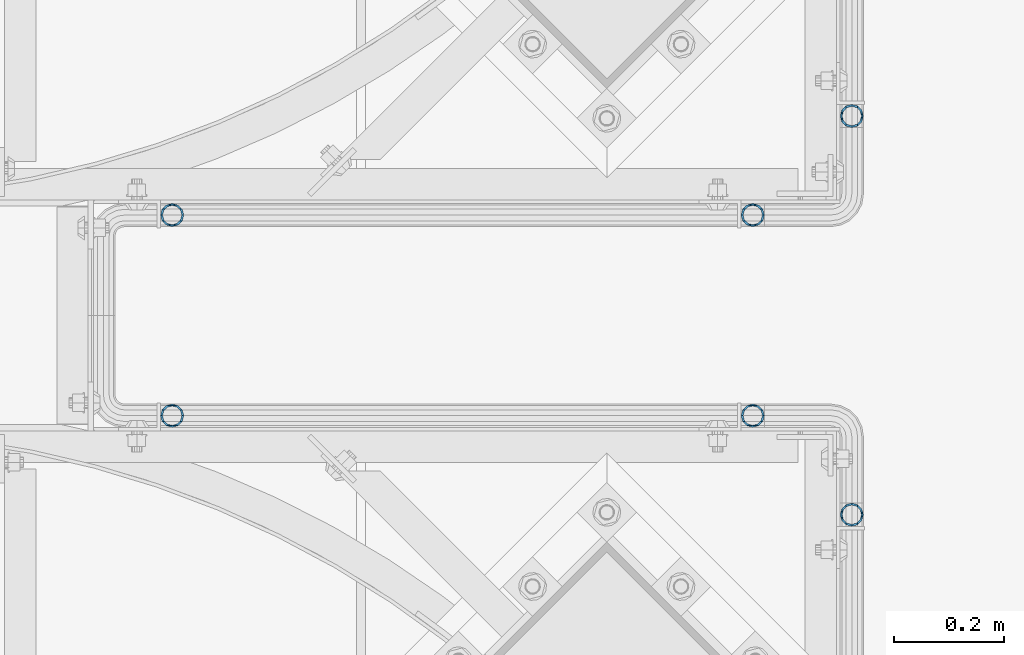
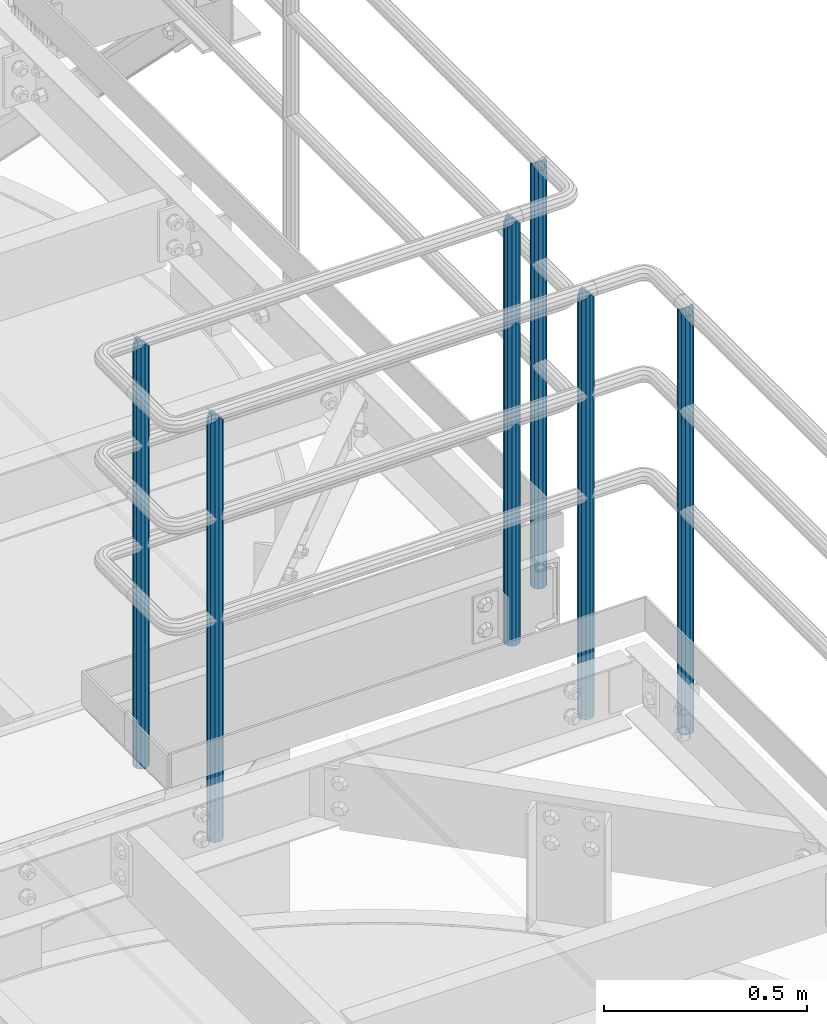
# One storey, part 553 of 1876: 6 columns, 4 elements without a shape of their own.
"""IFC2X3 building model written with IfcOpenShell, lengths in millimetres."""

from ifc_helpers import new_model, si_unit, frame, origin_with_axes, place, context, subcontext, project, spatial, faceted_brep, material, type_object, element, aggregate, save


model = new_model("IFC2X3")

# Units and contexts
model_context = context("Model", 3, precision=1e-05, world=origin_with_axes())
body_context = subcontext(model_context, "Body", "Model", "MODEL_VIEW")
ifc_project = project(units=[si_unit("LENGTHUNIT", "METRE", prefix="MILLI"), si_unit("AREAUNIT", "SQUARE_METRE"), si_unit("VOLUMEUNIT", "CUBIC_METRE"), si_unit("MASSUNIT", "GRAM", prefix="KILO"), si_unit("TIMEUNIT", "SECOND"), si_unit("PLANEANGLEUNIT", "RADIAN"), si_unit("SOLIDANGLEUNIT", "STERADIAN"), si_unit("THERMODYNAMICTEMPERATUREUNIT", "DEGREE_CELSIUS"), si_unit("LUMINOUSINTENSITYUNIT", "LUMEN")], contexts=[model_context])

# Site, building, storey
site_placement = place(None, origin_with_axes())
site = spatial("IfcSite", under=ifc_project, at=site_placement, CompositionType="ELEMENT")
building_placement = place(site_placement, origin_with_axes())
building = spatial("IfcBuilding", under=site, at=building_placement, Name="Undefined", CompositionType="ELEMENT")
storey_placement = place(building_placement, origin_with_axes())
storey = spatial("IfcBuildingStorey", under=building, at=storey_placement, Name="Undefined", CompositionType="ELEMENT", Elevation=0.0)

# Assembly, columns
assembly_1_placement = place(storey_placement, origin_with_axes())
assembly_1 = element("IfcElementAssembly", 1, at=assembly_1_placement, inside=storey, Name="HANDRAIL", AssemblyPlace="NOTDEFINED", PredefinedType="RIGID_FRAME")
ifc_material = material()
column_type = type_object("IfcColumnType", Name="PIPE1-1/4STD", PredefinedType="NOTDEFINED")
column_1_placement = place(assembly_1_placement, frame((6845.30474593762, -11381.1963554687, 7813.675), z_axis=(0.0, 1.0, 0.0), x_axis=(0.0, 0.0, 1.0)))
column_1 = element("IfcColumn", 2, at=column_1_placement, type_object=column_type, material=ifc_material, Name="POST", ObjectType="PIPE1-1/4STD", context=body_context, shape_type="Brep", body=[
    faceted_brep([(1276.35, 0.0, -21.0820000000003), (1265.809, 10.5410000000002, -18.2575475625836), (1265.809, -10.5410000000002, -18.2575475625836), (1257.61603877328, 15.1779612267264, 8.76299999999992), (1255.268, 17.5259999999998, 0.0), (1255.268, 21.0820000000003, 0.0), (1258.09245243742, 18.2575475625836, 10.5410000000002), (1258.09245243742, 13.3999612267262, 10.5410000000002), (1258.09245243742, 13.3999612267262, -10.5410000000002), (1258.09245243742, 18.2575475625836, -10.5410000000002), (1257.61603877328, 15.1779612267264, -8.76299999999992), (1262.72937633681, 8.76299999999992, -15.1779612267255), (1265.07741511008, 0.0, -17.5259999999998), (1262.72937633681, -8.76299999999992, -15.1779612267255), (1258.09245243741, -13.3999612267244, -10.541000000002), (1258.09245243742, -18.2575475625836, -10.5409999999993), (1257.61602877145, -15.1779612267264, -8.76300000000083), (1255.268, -17.5259999999998, 0.0), (1255.268, -21.0820000000003, 0.0), (1257.61604877511, -15.1779612267264, 8.76300000000083), (1258.09245243741, -13.399961226728, 10.5409999999983), (1258.09245243742, -18.2575475625836, 10.5409999999993), (1276.35, 0.0, 21.0820000000003), (1265.809, -10.5410000000002, 18.2575475625836), (1265.809, 10.5410000000002, 18.2575475625836), (1262.72941366414, -8.76299999999992, 15.1779612267264), (1265.07745243742, 0.0, 17.5259999999998), (1262.72941366414, 8.76299999999992, 15.1779612267264), (0.0, -18.2575475625836, -10.5409999999993), (0.0, -10.5410000000002, -18.2575475625836), (-4.28826751885936e-09, 0.0, -21.0820000000003), (0.0, 10.5410000000002, -18.2575475625836), (0.0, 18.2575475625836, -10.5409999999993), (9.09494701772928e-13, 21.0820000000003, 0.0), (0.0, 18.2575475625836, 10.5409999999993), (0.0, 10.5410000000002, 18.2575475625836), (0.0, 0.0, 21.0820000000003), (0.0, -18.2575475625836, 10.5409999999993), (9.09494701772928e-13, -21.0820000000003, 0.0), (0.0, -10.5410000000002, 18.2575475625836), (0.0, -15.1779612267264, -8.76300000000083), (0.0, -8.76299999999992, -15.1779612267255), (0.0, 0.0, -17.5259999999998), (0.0, 8.76299999999992, -15.1779612267255), (0.0, 15.1779612267264, -8.76300000000083), (0.0, 17.5259999999998, 0.0), (0.0, 15.1779612267264, 8.76300000000083), (0.0, 8.76299999999992, 15.1779612267255), (0.0, 0.0, 17.5259999999998), (0.0, -8.76299999999992, 15.1779612267255), (0.0, -15.1779612267264, 8.76300000000083), (0.0, -17.5259999999998, 0.0)], [[[0, 1, 2]], [[3, 4, 5, 6, 7]], [[8, 9, 5, 4, 10]], [[2, 1, 9, 8, 11, 12, 13, 14, 15]], [[15, 14, 16, 17, 18]], [[18, 17, 19, 20, 21]], [[22, 23, 24]], [[21, 20, 25, 26, 27, 7, 6, 24, 23]], [[28, 29, 2, 15]], [[29, 30, 0, 2]], [[30, 31, 1, 0]], [[31, 32, 9, 1]], [[32, 33, 5, 9]], [[33, 34, 6, 5]], [[34, 35, 24, 6]], [[35, 36, 22, 24]], [[37, 38, 18, 21]], [[39, 37, 21, 23]], [[36, 39, 23, 22]], [[38, 28, 15, 18]], [[37, 39, 36, 35, 34, 33, 32, 31, 30, 29, 28, 38], [40, 41, 42, 43, 44, 45, 46, 47, 48, 49, 50, 51]], [[49, 48, 26, 25]], [[19, 50, 49, 25, 20]], [[51, 50, 19, 17]], [[40, 51, 17, 16]], [[41, 40, 16, 14, 13]], [[42, 41, 13, 12]], [[43, 42, 12, 11]], [[10, 44, 43, 11, 8]], [[45, 44, 10, 4]], [[46, 45, 4, 3]], [[47, 46, 3, 7, 27]], [[48, 47, 27, 26]]]),
])
column_2_placement = place(assembly_1_placement, frame((5791.20474593762, -11381.1963554687, 7813.675), z_axis=(0.0, 1.0, 0.0), x_axis=(0.0, 0.0, 1.0)))
column_2 = element("IfcColumn", 3, at=column_2_placement, type_object=column_type, material=ifc_material, Name="POST", ObjectType="PIPE1-1/4STD", context=body_context, shape_type="Brep", body=[
    faceted_brep([(1276.35, 0.0, -21.0820000000003), (1265.809, 10.5410000000002, -18.2575475625836), (1265.809, -10.5410000000002, -18.2575475625836), (1257.61603877328, 15.1779612267264, 8.76299999999992), (1255.268, 17.5259999999998, 0.0), (1255.268, 21.0820000000003, 0.0), (1258.09245243742, 18.2575475625836, 10.5410000000002), (1258.09245243742, 13.3999612267262, 10.5410000000002), (1258.09245243742, 13.3999612267262, -10.5410000000002), (1258.09245243742, 18.2575475625836, -10.5410000000002), (1257.61603877328, 15.1779612267264, -8.76299999999992), (1262.72937633681, 8.76299999999992, -15.1779612267255), (1265.07741511008, 0.0, -17.5259999999998), (1262.72937633681, -8.76299999999992, -15.1779612267255), (1258.09245243741, -13.3999612267244, -10.541000000002), (1258.09245243742, -18.2575475625836, -10.5409999999993), (1257.61602877145, -15.1779612267264, -8.76300000000083), (1255.268, -17.5259999999998, 0.0), (1255.268, -21.0820000000003, 0.0), (1257.61604877511, -15.1779612267264, 8.76300000000083), (1258.09245243741, -13.399961226728, 10.5409999999983), (1258.09245243742, -18.2575475625836, 10.5409999999993), (1276.35, 0.0, 21.0820000000003), (1265.809, -10.5410000000002, 18.2575475625836), (1265.809, 10.5410000000002, 18.2575475625836), (1262.72941366414, -8.76299999999992, 15.1779612267264), (1265.07745243742, 0.0, 17.5259999999998), (1262.72941366414, 8.76299999999992, 15.1779612267264), (0.0, -18.2575475625836, -10.5409999999993), (0.0, -10.5410000000002, -18.2575475625836), (-4.28826751885936e-09, 0.0, -21.0820000000003), (0.0, 10.5410000000002, -18.2575475625836), (0.0, 18.2575475625836, -10.5409999999993), (9.09494701772928e-13, 21.0820000000003, 0.0), (0.0, 18.2575475625836, 10.5409999999993), (0.0, 10.5410000000002, 18.2575475625836), (0.0, 0.0, 21.0820000000003), (0.0, -18.2575475625836, 10.5409999999993), (9.09494701772928e-13, -21.0820000000003, 0.0), (0.0, -10.5410000000002, 18.2575475625836), (0.0, -15.1779612267264, -8.76300000000083), (0.0, -8.76299999999992, -15.1779612267255), (0.0, 0.0, -17.5259999999998), (0.0, 8.76299999999992, -15.1779612267255), (0.0, 15.1779612267264, -8.76300000000083), (0.0, 17.5259999999998, 0.0), (0.0, 15.1779612267264, 8.76300000000083), (0.0, 8.76299999999992, 15.1779612267255), (0.0, 0.0, 17.5259999999998), (0.0, -8.76299999999992, 15.1779612267255), (0.0, -15.1779612267264, 8.76300000000083), (0.0, -17.5259999999998, 0.0)], [[[0, 1, 2]], [[3, 4, 5, 6, 7]], [[8, 9, 5, 4, 10]], [[2, 1, 9, 8, 11, 12, 13, 14, 15]], [[15, 14, 16, 17, 18]], [[18, 17, 19, 20, 21]], [[22, 23, 24]], [[21, 20, 25, 26, 27, 7, 6, 24, 23]], [[28, 29, 2, 15]], [[29, 30, 0, 2]], [[30, 31, 1, 0]], [[31, 32, 9, 1]], [[32, 33, 5, 9]], [[33, 34, 6, 5]], [[34, 35, 24, 6]], [[35, 36, 22, 24]], [[37, 38, 18, 21]], [[39, 37, 21, 23]], [[36, 39, 23, 22]], [[38, 28, 15, 18]], [[37, 39, 36, 35, 34, 33, 32, 31, 30, 29, 28, 38], [40, 41, 42, 43, 44, 45, 46, 47, 48, 49, 50, 51]], [[49, 48, 26, 25]], [[19, 50, 49, 25, 20]], [[51, 50, 19, 17]], [[40, 51, 17, 16]], [[41, 40, 16, 14, 13]], [[42, 41, 13, 12]], [[43, 42, 12, 11]], [[10, 44, 43, 11, 8]], [[45, 44, 10, 4]], [[46, 45, 4, 3]], [[47, 46, 3, 7, 27]], [[48, 47, 27, 26]]]),
])
aggregate(assembly_1, [column_1, column_2])

# Assembly, column
assembly_2_placement = place(storey_placement, origin_with_axes())
assembly_2 = element("IfcElementAssembly", 4, at=assembly_2_placement, inside=storey, Name="HANDRAIL", AssemblyPlace="NOTDEFINED", PredefinedType="RIGID_FRAME")
column_3_placement = place(assembly_2_placement, frame((7025.13388293519, -11201.3643554687, 7813.675), z_axis=(0.0, 1.0, 0.0), x_axis=(0.0, 0.0, 1.0)))
column_3 = element("IfcColumn", 5, at=column_3_placement, type_object=column_type, material=ifc_material, Name="POST", ObjectType="PIPE1-1/4STD", context=body_context, shape_type="Brep", body=[
    faceted_brep([(1258.09245243742, -10.5410000000002, 18.2575475625836), (1258.09245243742, -10.5410017746963, 13.3999594520301), (1257.61603823465, -8.76299999999992, 15.1779612267255), (1255.268, 0.0, 17.5259999999998), (1255.268, 0.0, 21.0820000000003), (1257.6160393119, 8.76299999999992, 15.1779612267255), (1258.09245243742, 10.5409982253032, 13.3999630014223), (1258.09245243742, 10.5410000000002, 18.2575475625836), (1276.35, 21.0820000000003, 0.0), (1265.809, 18.2575475625836, 10.5410000000002), (1265.809, 18.2575475625836, -10.5410000000002), (1262.72941482472, 15.1779612267264, 8.76300000000083), (1265.07745243742, 17.5259999999998, 0.0), (1262.72941250358, 15.1779612267264, -8.76300000000083), (1258.09245243742, 10.5410000000002, -13.3999612267253), (1258.09245243742, 10.5410000000002, -18.2575475625836), (1257.61603877328, 8.76299999999992, -15.1779612267255), (1255.268, 0.0, -17.5259999999998), (1255.268, 0.0, -21.0820000000003), (1258.09245243742, -10.5410000000002, -13.3999612267253), (1258.09245243742, -10.5410000000002, -18.2575475625836), (1257.61603877328, -8.76299999999992, -15.1779612267255), (1276.35000278283, -21.0820000000003, 0.0), (1265.809, -18.2575475625836, -10.5410000000002), (1265.809, -18.2575475625836, 10.5410000000002), (1262.72941366414, -15.1779612267264, -8.76300000000083), (1265.07745243742, -17.5259999999998, 0.0), (1262.72941366414, -15.1779612267264, 8.76300000000083), (0.0, -18.2575475625836, -10.5409999999993), (0.0, -10.5410000000002, -18.2575475625836), (-4.28826751885936e-09, 0.0, -21.0820000000003), (0.0, 10.5410000000002, -18.2575475625836), (0.0, 18.2575475625836, -10.5409999999993), (9.09494701772928e-13, 21.0820000000003, 0.0), (0.0, 18.2575475625836, 10.5409999999993), (0.0, 10.5410000000002, 18.2575475625836), (0.0, 0.0, 21.0820000000003), (0.0, -10.5410000000002, 18.2575475625836), (0.0, -18.2575475625836, 10.5409999999993), (9.09494701772928e-13, -21.0820000000003, 0.0), (0.0, -15.1779612267264, -8.76300000000083), (0.0, -8.76299999999992, -15.1779612267255), (0.0, 0.0, -17.5259999999998), (0.0, 8.76299999999992, -15.1779612267255), (0.0, 15.1779612267264, -8.76300000000083), (0.0, 17.5259999999998, 0.0), (0.0, 15.1779612267264, 8.76300000000083), (0.0, 8.76299999999992, 15.1779612267255), (0.0, 0.0, 17.5259999999998), (0.0, -8.76299999999992, 15.1779612267255), (0.0, -15.1779612267264, 8.76300000000083), (0.0, -17.5259999999998, 0.0)], [[[0, 1, 2, 3, 4]], [[4, 3, 5, 6, 7]], [[8, 9, 10]], [[7, 6, 11, 12, 13, 14, 15, 10, 9]], [[16, 17, 18, 15, 14]], [[19, 20, 18, 17, 21]], [[22, 23, 24]], [[24, 23, 20, 19, 25, 26, 27, 1, 0]], [[28, 29, 20, 23]], [[29, 30, 18, 20]], [[30, 31, 15, 18]], [[31, 32, 10, 15]], [[32, 33, 8, 10]], [[33, 34, 9, 8]], [[34, 35, 7, 9]], [[35, 36, 4, 7]], [[36, 37, 0, 4]], [[37, 38, 24, 0]], [[38, 39, 22, 24]], [[39, 28, 23, 22]], [[38, 37, 36, 35, 34, 33, 32, 31, 30, 29, 28, 39], [40, 41, 42, 43, 44, 45, 46, 47, 48, 49, 50, 51]], [[40, 51, 26, 25]], [[21, 41, 40, 25, 19]], [[42, 41, 21, 17]], [[43, 42, 17, 16]], [[44, 43, 16, 14, 13]], [[45, 44, 13, 12]], [[46, 45, 12, 11]], [[5, 47, 46, 11, 6]], [[48, 47, 5, 3]], [[49, 48, 3, 2]], [[50, 49, 2, 1, 27]], [[51, 50, 27, 26]]]),
])
aggregate(assembly_2, [column_3])

# Assembly, columns
assembly_3_placement = place(storey_placement, origin_with_axes())
assembly_3 = element("IfcElementAssembly", 6, at=assembly_3_placement, inside=storey, Name="HANDRAIL", AssemblyPlace="NOTDEFINED", PredefinedType="RIGID_FRAME")
column_4_placement = place(assembly_3_placement, frame((6845.30143150122, -11745.4324531238, 7813.675), z_axis=(0.0, 1.0, 0.0), x_axis=(0.0, 0.0, 1.0)))
column_4 = element("IfcColumn", 7, at=column_4_placement, type_object=column_type, material=ifc_material, Name="POST", ObjectType="PIPE1-1/4STD", context=body_context, shape_type="Brep", body=[
    faceted_brep([(1276.35, 0.0, -21.0820000000003), (1265.809, 10.5410000000002, -18.2575475625836), (1265.809, -10.5410000000002, -18.2575475625836), (1257.61603877328, 15.1779612267264, 8.76299999999992), (1255.268, 17.5259999999998, 0.0), (1255.268, 21.0820000000003, 0.0), (1258.09245243742, 18.2575475625836, 10.5410000000002), (1258.09245243742, 13.3999612267262, 10.5410000000002), (1258.09245243742, 13.3999612267262, -10.5410000000002), (1258.09245243742, 18.2575475625836, -10.5410000000002), (1257.61603877328, 15.1779612267264, -8.76299999999992), (1262.72937633681, 8.76299999999992, -15.1779612267255), (1265.07741511008, 0.0, -17.5259999999998), (1262.72937633681, -8.76299999999992, -15.1779612267255), (1258.09245243741, -13.3999612267244, -10.541000000002), (1258.09245243742, -18.2575475625836, -10.5409999999993), (1257.61602877145, -15.1779612267264, -8.76300000000083), (1255.268, -17.5259999999998, 0.0), (1255.268, -21.0820000000003, 0.0), (1257.61604877511, -15.1779612267264, 8.76300000000083), (1258.09245243741, -13.399961226728, 10.5409999999983), (1258.09245243742, -18.2575475625836, 10.5409999999993), (1276.35, 0.0, 21.0820000000003), (1265.809, -10.5410000000002, 18.2575475625836), (1265.809, 10.5410000000002, 18.2575475625836), (1262.72941366414, -8.76299999999992, 15.1779612267264), (1265.07745243742, 0.0, 17.5259999999998), (1262.72941366414, 8.76299999999992, 15.1779612267264), (0.0, -18.2575475625836, -10.5409999999993), (0.0, -10.5410000000002, -18.2575475625836), (-4.28826751885936e-09, 0.0, -21.0820000000003), (0.0, 10.5410000000002, -18.2575475625836), (0.0, 18.2575475625836, -10.5409999999993), (9.09494701772928e-13, 21.0820000000003, 0.0), (0.0, 18.2575475625836, 10.5409999999993), (0.0, 10.5410000000002, 18.2575475625836), (0.0, 0.0, 21.0820000000003), (0.0, -18.2575475625836, 10.5409999999993), (9.09494701772928e-13, -21.0820000000003, 0.0), (0.0, -10.5410000000002, 18.2575475625836), (0.0, -15.1779612267264, -8.76300000000083), (0.0, -8.76299999999992, -15.1779612267255), (0.0, 0.0, -17.5259999999998), (0.0, 8.76299999999992, -15.1779612267255), (0.0, 15.1779612267264, -8.76300000000083), (0.0, 17.5259999999998, 0.0), (0.0, 15.1779612267264, 8.76300000000083), (0.0, 8.76299999999992, 15.1779612267255), (0.0, 0.0, 17.5259999999998), (0.0, -8.76299999999992, 15.1779612267255), (0.0, -15.1779612267264, 8.76300000000083), (0.0, -17.5259999999998, 0.0)], [[[0, 1, 2]], [[3, 4, 5, 6, 7]], [[8, 9, 5, 4, 10]], [[2, 1, 9, 8, 11, 12, 13, 14, 15]], [[15, 14, 16, 17, 18]], [[18, 17, 19, 20, 21]], [[22, 23, 24]], [[21, 20, 25, 26, 27, 7, 6, 24, 23]], [[28, 29, 2, 15]], [[29, 30, 0, 2]], [[30, 31, 1, 0]], [[31, 32, 9, 1]], [[32, 33, 5, 9]], [[33, 34, 6, 5]], [[34, 35, 24, 6]], [[35, 36, 22, 24]], [[37, 38, 18, 21]], [[39, 37, 21, 23]], [[36, 39, 23, 22]], [[38, 28, 15, 18]], [[37, 39, 36, 35, 34, 33, 32, 31, 30, 29, 28, 38], [40, 41, 42, 43, 44, 45, 46, 47, 48, 49, 50, 51]], [[49, 48, 26, 25]], [[19, 50, 49, 25, 20]], [[51, 50, 19, 17]], [[40, 51, 17, 16]], [[41, 40, 16, 14, 13]], [[42, 41, 13, 12]], [[43, 42, 12, 11]], [[10, 44, 43, 11, 8]], [[45, 44, 10, 4]], [[46, 45, 4, 3]], [[47, 46, 3, 7, 27]], [[48, 47, 27, 26]]]),
])
column_5_placement = place(assembly_3_placement, frame((5791.20143150122, -11745.4324531238, 7813.675), z_axis=(0.0, 1.0, 0.0), x_axis=(0.0, 0.0, 1.0)))
column_5 = element("IfcColumn", 8, at=column_5_placement, type_object=column_type, material=ifc_material, Name="POST", ObjectType="PIPE1-1/4STD", context=body_context, shape_type="Brep", body=[
    faceted_brep([(1276.35, 0.0, -21.0820000000003), (1265.809, 10.5410000000002, -18.2575475625836), (1265.809, -10.5410000000002, -18.2575475625836), (1257.61603877328, 15.1779612267264, 8.76299999999992), (1255.268, 17.5259999999998, 0.0), (1255.268, 21.0820000000003, 0.0), (1258.09245243742, 18.2575475625836, 10.5410000000002), (1258.09245243742, 13.3999612267262, 10.5410000000002), (1258.09245243742, 13.3999612267262, -10.5410000000002), (1258.09245243742, 18.2575475625836, -10.5410000000002), (1257.61603877328, 15.1779612267264, -8.76299999999992), (1262.72937633681, 8.76299999999992, -15.1779612267255), (1265.07741511008, 0.0, -17.5259999999998), (1262.72937633681, -8.76299999999992, -15.1779612267255), (1258.09245243741, -13.3999612267244, -10.541000000002), (1258.09245243742, -18.2575475625836, -10.5409999999993), (1257.61602877145, -15.1779612267264, -8.76300000000083), (1255.268, -17.5259999999998, 0.0), (1255.268, -21.0820000000003, 0.0), (1257.61604877511, -15.1779612267264, 8.76300000000083), (1258.09245243741, -13.399961226728, 10.5409999999983), (1258.09245243742, -18.2575475625836, 10.5409999999993), (1276.35, 0.0, 21.0820000000003), (1265.809, -10.5410000000002, 18.2575475625836), (1265.809, 10.5410000000002, 18.2575475625836), (1262.72941366414, -8.76299999999992, 15.1779612267264), (1265.07745243742, 0.0, 17.5259999999998), (1262.72941366414, 8.76299999999992, 15.1779612267264), (0.0, -18.2575475625836, -10.5409999999993), (0.0, -10.5410000000002, -18.2575475625836), (-4.28826751885936e-09, 0.0, -21.0820000000003), (0.0, 10.5410000000002, -18.2575475625836), (0.0, 18.2575475625836, -10.5409999999993), (9.09494701772928e-13, 21.0820000000003, 0.0), (0.0, 18.2575475625836, 10.5409999999993), (0.0, 10.5410000000002, 18.2575475625836), (0.0, 0.0, 21.0820000000003), (0.0, -18.2575475625836, 10.5409999999993), (9.09494701772928e-13, -21.0820000000003, 0.0), (0.0, -10.5410000000002, 18.2575475625836), (0.0, -15.1779612267264, -8.76300000000083), (0.0, -8.76299999999992, -15.1779612267255), (0.0, 0.0, -17.5259999999998), (0.0, 8.76299999999992, -15.1779612267255), (0.0, 15.1779612267264, -8.76300000000083), (0.0, 17.5259999999998, 0.0), (0.0, 15.1779612267264, 8.76300000000083), (0.0, 8.76299999999992, 15.1779612267255), (0.0, 0.0, 17.5259999999998), (0.0, -8.76299999999992, 15.1779612267255), (0.0, -15.1779612267264, 8.76300000000083), (0.0, -17.5259999999998, 0.0)], [[[0, 1, 2]], [[3, 4, 5, 6, 7]], [[8, 9, 5, 4, 10]], [[2, 1, 9, 8, 11, 12, 13, 14, 15]], [[15, 14, 16, 17, 18]], [[18, 17, 19, 20, 21]], [[22, 23, 24]], [[21, 20, 25, 26, 27, 7, 6, 24, 23]], [[28, 29, 2, 15]], [[29, 30, 0, 2]], [[30, 31, 1, 0]], [[31, 32, 9, 1]], [[32, 33, 5, 9]], [[33, 34, 6, 5]], [[34, 35, 24, 6]], [[35, 36, 22, 24]], [[37, 38, 18, 21]], [[39, 37, 21, 23]], [[36, 39, 23, 22]], [[38, 28, 15, 18]], [[37, 39, 36, 35, 34, 33, 32, 31, 30, 29, 28, 38], [40, 41, 42, 43, 44, 45, 46, 47, 48, 49, 50, 51]], [[49, 48, 26, 25]], [[19, 50, 49, 25, 20]], [[51, 50, 19, 17]], [[40, 51, 17, 16]], [[41, 40, 16, 14, 13]], [[42, 41, 13, 12]], [[43, 42, 12, 11]], [[10, 44, 43, 11, 8]], [[45, 44, 10, 4]], [[46, 45, 4, 3]], [[47, 46, 3, 7, 27]], [[48, 47, 27, 26]]]),
])
aggregate(assembly_3, [column_4, column_5])

# Assembly, column
assembly_4_placement = place(storey_placement, origin_with_axes())
assembly_4 = element("IfcElementAssembly", 9, at=assembly_4_placement, inside=storey, Name="HANDRAIL", AssemblyPlace="NOTDEFINED", PredefinedType="RIGID_FRAME")
column_6_placement = place(assembly_4_placement, frame((7025.13056849878, -11925.2644042969, 7813.675), z_axis=(0.0, 1.0, 0.0), x_axis=(0.0, 0.0, 1.0)))
column_6 = element("IfcColumn", 10, at=column_6_placement, type_object=column_type, material=ifc_material, Name="POST", ObjectType="PIPE1-1/4STD", context=body_context, shape_type="Brep", body=[
    faceted_brep([(1258.09245243742, -10.5410000000002, 18.2575475625836), (1258.09245243742, -10.5410017746963, 13.3999594520301), (1257.61603823465, -8.76299999999992, 15.1779612267255), (1255.268, 0.0, 17.5259999999998), (1255.268, 0.0, 21.0820000000003), (1257.6160393119, 8.76299999999992, 15.1779612267255), (1258.09245243742, 10.5409982253032, 13.3999630014223), (1258.09245243742, 10.5410000000002, 18.2575475625836), (1276.35, 21.0820000000003, 0.0), (1265.809, 18.2575475625836, 10.5410000000002), (1265.809, 18.2575475625836, -10.5410000000002), (1262.72941482472, 15.1779612267264, 8.76300000000083), (1265.07745243742, 17.5259999999998, 0.0), (1262.72941250358, 15.1779612267264, -8.76300000000083), (1258.09245243742, 10.5410000000002, -13.3999612267253), (1258.09245243742, 10.5410000000002, -18.2575475625836), (1257.61603877328, 8.76299999999992, -15.1779612267255), (1255.268, 0.0, -17.5259999999998), (1255.268, 0.0, -21.0820000000003), (1258.09245243742, -10.5410000000002, -13.3999612267253), (1258.09245243742, -10.5410000000002, -18.2575475625836), (1257.61603877328, -8.76299999999992, -15.1779612267255), (1276.35000278283, -21.0820000000003, 0.0), (1265.809, -18.2575475625836, -10.5410000000002), (1265.809, -18.2575475625836, 10.5410000000002), (1262.72941366414, -15.1779612267264, -8.76300000000083), (1265.07745243742, -17.5259999999998, 0.0), (1262.72941366414, -15.1779612267264, 8.76300000000083), (0.0, -18.2575475625836, -10.5409999999993), (0.0, -10.5410000000002, -18.2575475625836), (-4.28826751885936e-09, 0.0, -21.0820000000003), (0.0, 10.5410000000002, -18.2575475625836), (0.0, 18.2575475625836, -10.5409999999993), (9.09494701772928e-13, 21.0820000000003, 0.0), (0.0, 18.2575475625836, 10.5409999999993), (0.0, 10.5410000000002, 18.2575475625836), (0.0, 0.0, 21.0820000000003), (0.0, -10.5410000000002, 18.2575475625836), (0.0, -18.2575475625836, 10.5409999999993), (9.09494701772928e-13, -21.0820000000003, 0.0), (0.0, -15.1779612267264, -8.76300000000083), (0.0, -8.76299999999992, -15.1779612267255), (0.0, 0.0, -17.5259999999998), (0.0, 8.76299999999992, -15.1779612267255), (0.0, 15.1779612267264, -8.76300000000083), (0.0, 17.5259999999998, 0.0), (0.0, 15.1779612267264, 8.76300000000083), (0.0, 8.76299999999992, 15.1779612267255), (0.0, 0.0, 17.5259999999998), (0.0, -8.76299999999992, 15.1779612267255), (0.0, -15.1779612267264, 8.76300000000083), (0.0, -17.5259999999998, 0.0)], [[[0, 1, 2, 3, 4]], [[4, 3, 5, 6, 7]], [[8, 9, 10]], [[7, 6, 11, 12, 13, 14, 15, 10, 9]], [[16, 17, 18, 15, 14]], [[19, 20, 18, 17, 21]], [[22, 23, 24]], [[24, 23, 20, 19, 25, 26, 27, 1, 0]], [[28, 29, 20, 23]], [[29, 30, 18, 20]], [[30, 31, 15, 18]], [[31, 32, 10, 15]], [[32, 33, 8, 10]], [[33, 34, 9, 8]], [[34, 35, 7, 9]], [[35, 36, 4, 7]], [[36, 37, 0, 4]], [[37, 38, 24, 0]], [[38, 39, 22, 24]], [[39, 28, 23, 22]], [[38, 37, 36, 35, 34, 33, 32, 31, 30, 29, 28, 39], [40, 41, 42, 43, 44, 45, 46, 47, 48, 49, 50, 51]], [[40, 51, 26, 25]], [[21, 41, 40, 25, 19]], [[42, 41, 21, 17]], [[43, 42, 17, 16]], [[44, 43, 16, 14, 13]], [[45, 44, 13, 12]], [[46, 45, 12, 11]], [[5, 47, 46, 11, 6]], [[48, 47, 5, 3]], [[49, 48, 3, 2]], [[50, 49, 2, 1, 27]], [[51, 50, 27, 26]]]),
])
aggregate(assembly_4, [column_6])

save(model, "model.ifc")
